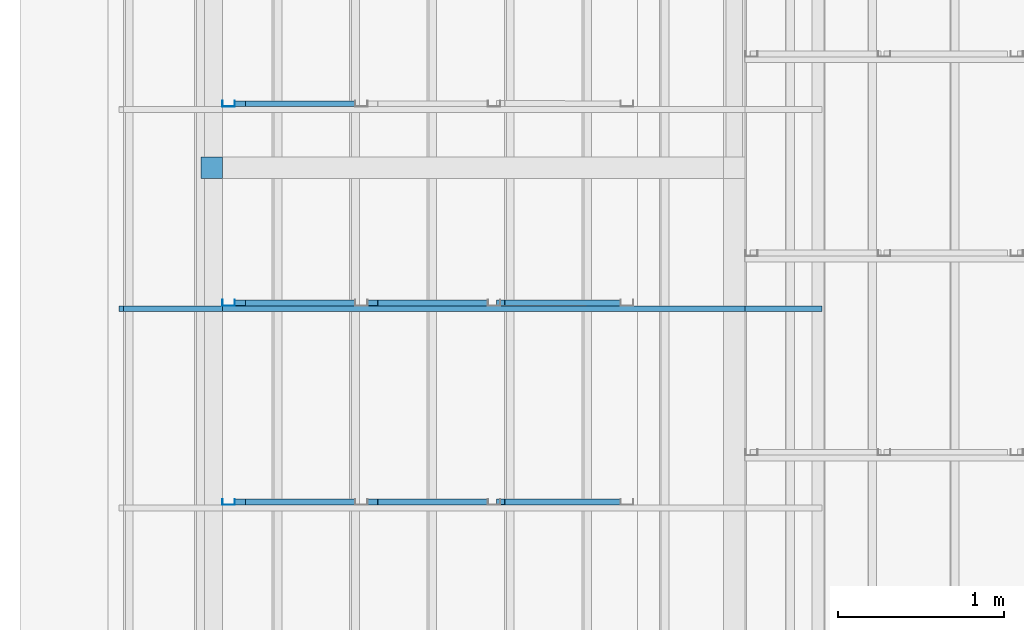
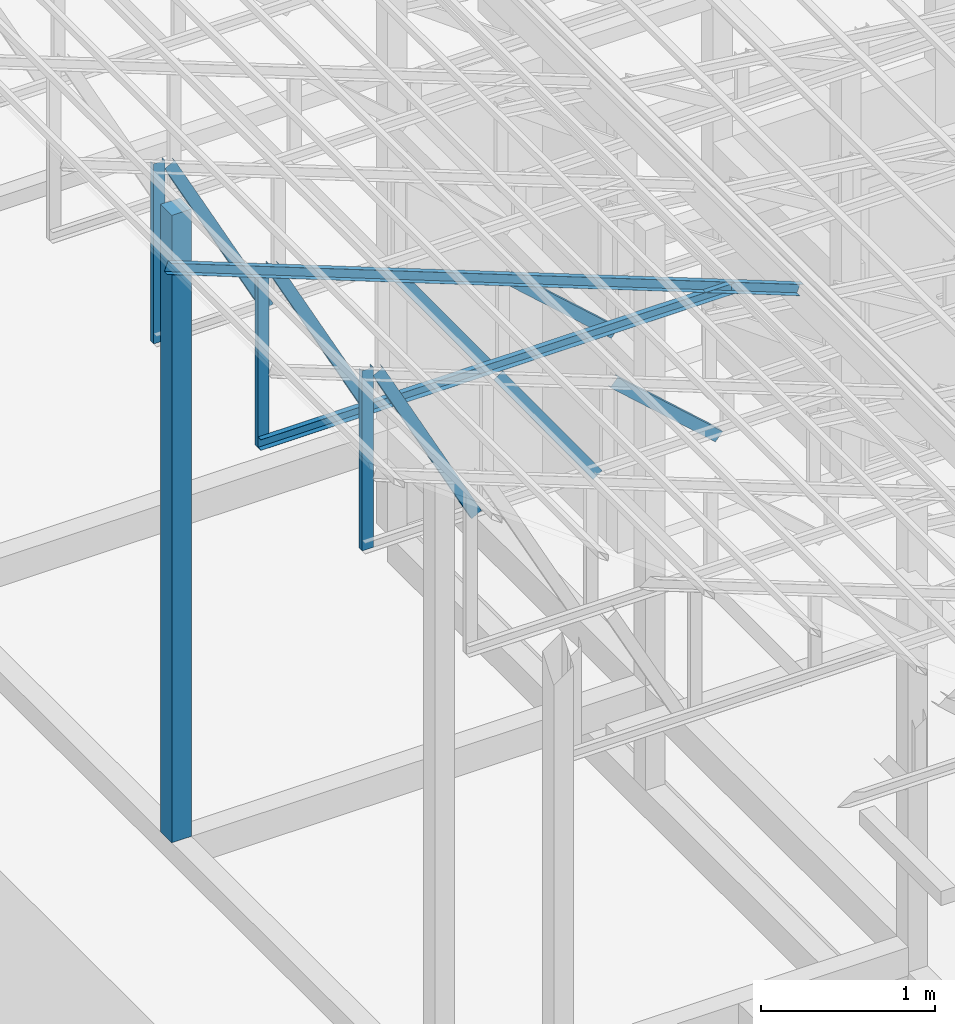
# One storey, part 11 of 22: 12 members, 1 beam, 1 element without a shape of its own.
"""IFC4 building model written with IfcOpenShell, lengths in millimetres."""

from ifc_helpers import new_model, entity, si_unit, converted_unit, frame, origin_with_axes, origin_2d_with_axis, place, context, subcontext, project, spatial, rectangle, c_section, extrude, material, material_profile, profile_set, profile_usage, type_object, element, aggregate, save


model = new_model("IFC4")

# Units and contexts
model_context = context("Model", 3, precision=1e-05, world=origin_with_axes())
plan_context = context("Plan", 2, precision=1e-05, world=origin_2d_with_axis())
body_context = subcontext(model_context, "Body", "Model", "MODEL_VIEW")
ifc_project = project(units=[si_unit("VOLUMEUNIT", "CUBIC_METRE"), si_unit("LENGTHUNIT", "METRE", prefix="MILLI"), si_unit("AREAUNIT", "SQUARE_METRE"), converted_unit("PLANEANGLEUNIT", "degree", entity("IfcReal", 0.0174532925199433), si_unit("PLANEANGLEUNIT", "RADIAN"), dimensions=[0, 0, 0, 0, 0, 0, 0])], contexts=[model_context, plan_context])

# Site, building, storey
site_placement = place(None, origin_with_axes())
site = spatial("IfcSite", under=ifc_project, at=site_placement)
building_placement = place(site_placement, origin_with_axes())
building = spatial("IfcBuilding", under=site, at=building_placement, Name="2")
storey_placement = place(building_placement, frame((0.0, 0.0, 200.000002980232), z_axis=(0.0, 0.0, 1.0), x_axis=(1.0, 0.0, 0.0)))
storey = spatial("IfcBuildingStorey", under=building, at=storey_placement)

# Beam
ifc_material_1 = material(Name="Concrete")
ifc_material_profile_1 = material_profile(ifc_material_1, rectangle(XDim=130.000015258789, YDim=130.000015258789, kind="CURVE"))
ifc_profile_set_1 = profile_set([ifc_material_profile_1])
ifc_profile_usage_1 = profile_usage(ifc_profile_set_1, cardinal=5)
beam_type = type_object("IfcBeamType", PredefinedType="BEAM", material=ifc_profile_set_1)
beam_placement = place(storey_placement, frame((-7149.99771118164, 14330.0046920776, 735.000059008599), z_axis=(0.0, 0.0, 1.0), x_axis=(1.0, 0.0, 0.0)))
element("IfcBeam", 1, at=beam_placement, inside=storey, type_object=beam_type, material=ifc_profile_usage_1, Name="Column", PredefinedType="BEAM", context=body_context, shape_type="SweptSolid", body=[
    extrude(rectangle(XDim=130.000015258789, YDim=130.000015258789, kind="CURVE"), origin_with_axes(), (0.0, 0.0, 1.0), 4411.20902133499),
])

# Assembly, members
assembly_placement = place(storey_placement, frame((-3938.51041793823, 5099.00283813477, 3935.3459328413), z_axis=(0.0, 0.0, 1.0), x_axis=(1.0, 0.0, 0.0)))
assembly = element("IfcElementAssembly", 2, at=assembly_placement, inside=storey, Name="2")
ifc_material_2 = material(Name="STEEL")
ifc_material_profile_2 = material_profile(ifc_material_2, c_section(Depth=75.0, Width=35.0, WallThickness=1.0, Girth=1.0, kind="CURVE"))
ifc_profile_set_2 = profile_set([ifc_material_profile_2])
ifc_profile_usage_2 = profile_usage(ifc_profile_set_2, cardinal=3)
member_type = type_object("IfcMemberType", Name="C75", PredefinedType="CHORD", material=ifc_profile_set_2)
member_1_placement = place(assembly_placement, frame((-2271.51107788086, 7199.99885559082, 894.618034362793), z_axis=(0.578723368640778, -7.49756619914683e-07, -0.815523919078103), x_axis=(1.02917226740772e-06, 0.999999999999453, -1.89020340712783e-07)))
member_1 = element("IfcMember", 3, at=member_1_placement, type_object=member_type, material=ifc_profile_usage_2, Name="Member", context=body_context, shape_type="SweptSolid", body=[
    extrude(c_section(Depth=75.0, Width=35.0, WallThickness=1.0, Girth=1.0, kind="CURVE"), frame((17.5, 37.5, 0.0), z_axis=(0.0, 0.0, 1.0), x_axis=(1.0, 0.0, 0.0)), (0.0, 0.0, 1.0), 1142.30360336039),
])
ifc_profile_usage_3 = profile_usage(ifc_profile_set_2, cardinal=1)
member_2_placement = place(assembly_placement, frame((-3146.51107788086, 7234.99774932861, 1265.15865325928), z_axis=(-8.74227410463377e-08, -1.50995830949794e-07, -0.999999999999985), x_axis=(-3.13916473260159e-07, 0.999999999999939, -1.50995802528077e-07)))
member_2 = element("IfcMember", 4, at=member_2_placement, type_object=member_type, material=ifc_profile_usage_3, Name="Member", context=body_context, shape_type="SweptSolid", body=[
    extrude(c_section(Depth=75.0, Width=35.0, WallThickness=1.0, Girth=1.0, kind="CURVE"), frame((-17.5, 37.5, 0.0), z_axis=(0.0, 0.0, 1.0), x_axis=(1.0, 0.0, 0.0)), (0.0, 0.0, 1.0), 1266.51238309135),
])
ifc_profile_usage_4 = profile_usage(ifc_profile_set_2, cardinal=7)
member_3_placement = place(assembly_placement, frame((-1445.26290893555, 7235.96000671387, 624.074935913086), z_axis=(0.745142107017777, -0.00102660805644996, -0.66690493057482), x_axis=(0.00137753843534741, 0.999999051193456, -2.17762747561669e-07)))
member_3 = element("IfcMember", 5, at=member_3_placement, type_object=member_type, material=ifc_profile_usage_4, Name="Member", context=body_context, shape_type="SweptSolid", body=[
    extrude(c_section(Depth=75.0, Width=35.0, WallThickness=1.0, Girth=1.0, kind="CURVE"), frame((-17.5, -37.5, 0.0), z_axis=(0.0, 0.0, 1.0), x_axis=(1.0, 0.0, 0.0)), (0.0, 0.0, 1.0), 937.808496265298),
])
ifc_profile_usage_5 = profile_usage(ifc_profile_set_2, cardinal=9)
member_4_placement = place(assembly_placement, frame((-3006.42156600952, 7199.9979019165, 1241.45650863647), z_axis=(0.468464370953309, -3.43728484817469e-07, -0.88348238983423), x_axis=(6.7154434191237e-07, 0.999999999999774, -3.29761675743537e-08)))
member_4 = element("IfcMember", 6, at=member_4_placement, type_object=member_type, material=ifc_profile_usage_5, Name="Member", context=body_context, shape_type="SweptSolid", body=[
    extrude(c_section(Depth=75.0, Width=35.0, WallThickness=1.0, Girth=1.0, kind="CURVE"), frame((17.5, -37.5, 0.0), z_axis=(0.0, 0.0, 1.0), x_axis=(1.0, 0.0, 0.0)), (0.0, 0.0, 1.0), 1399.63894386164),
])
ifc_profile_usage_6 = profile_usage(ifc_profile_set_2, cardinal=3)
member_5_placement = place(assembly_placement, frame((-2271.51107788086, 8399.99866485596, 894.618034362793), z_axis=(0.578723368640778, -7.49756619914683e-07, -0.815523919078103), x_axis=(1.02917226740772e-06, 0.999999999999453, -1.89020340712783e-07)))
member_5 = element("IfcMember", 7, at=member_5_placement, type_object=member_type, material=ifc_profile_usage_6, Name="Member", context=body_context, shape_type="SweptSolid", body=[
    extrude(c_section(Depth=75.0, Width=35.0, WallThickness=1.0, Girth=1.0, kind="CURVE"), frame((17.5, 37.5, 0.0), z_axis=(0.0, 0.0, 1.0), x_axis=(1.0, 0.0, 0.0)), (0.0, 0.0, 1.0), 1142.30360336039),
])
ifc_profile_usage_7 = profile_usage(ifc_profile_set_2, cardinal=1)
member_6_placement = place(assembly_placement, frame((-3146.51107788086, 8434.99755859375, 1265.15865325928), z_axis=(-8.74227410463377e-08, -1.50995830949794e-07, -0.999999999999985), x_axis=(-3.13916473260159e-07, 0.999999999999939, -1.50995802528077e-07)))
member_6 = element("IfcMember", 8, at=member_6_placement, type_object=member_type, material=ifc_profile_usage_7, Name="Member", context=body_context, shape_type="SweptSolid", body=[
    extrude(c_section(Depth=75.0, Width=35.0, WallThickness=1.0, Girth=1.0, kind="CURVE"), frame((-17.5, 37.5, 0.0), z_axis=(0.0, 0.0, 1.0), x_axis=(1.0, 0.0, 0.0)), (0.0, 0.0, 1.0), 1266.51238309135),
])
ifc_profile_usage_8 = profile_usage(ifc_profile_set_2, cardinal=1)
member_7_placement = place(assembly_placement, frame((438.234329223633, 8364.99977111816, -169.034004211426), z_axis=(-0.933001152035968, -8.32115964913738e-07, 0.359873380925658), x_axis=(9.09962921013707e-07, -0.999999999999585, 4.6906695416718e-08)))
member_7 = element("IfcMember", 9, at=member_7_placement, type_object=member_type, material=ifc_profile_usage_8, Name="Member", context=body_context, shape_type="SweptSolid", body=[
    extrude(c_section(Depth=75.0, Width=35.0, WallThickness=1.0, Girth=1.0, kind="CURVE"), frame((-17.5, 37.5, 0.0), z_axis=(0.0, 0.0, 1.0), x_axis=(1.0, 0.0, 0.0)), (0.0, 0.0, 1.0), 4510.0754953159),
])
ifc_profile_usage_9 = profile_usage(ifc_profile_set_2, cardinal=1)
member_8_placement = place(assembly_placement, frame((3.51285934448242, 8364.99881744385, -1.35517120361328), z_axis=(-0.999999999999812, -4.33125762810878e-07, 4.33125762810878e-07), x_axis=(4.33125762810919e-07, -0.999999999999906, -1.13742348872837e-13)))
member_8 = element("IfcMember", 10, at=member_8_placement, type_object=member_type, material=ifc_profile_usage_9, Name="Member", context=body_context, shape_type="SweptSolid", body=[
    extrude(c_section(Depth=75.0, Width=35.0, WallThickness=1.0, Girth=1.0, kind="CURVE"), frame((-17.5, 37.5, 0.0), z_axis=(0.0, 0.0, 1.0), x_axis=(1.0, 0.0, 0.0)), (0.0, 0.0, 1.0), 3150.02386296032),
])
ifc_profile_usage_10 = profile_usage(ifc_profile_set_2, cardinal=7)
member_9_placement = place(assembly_placement, frame((-1445.26290893555, 8435.959815979, 624.074935913086), z_axis=(0.745142107017777, -0.00102660805644996, -0.66690493057482), x_axis=(0.00137753843534741, 0.999999051193456, -2.17762747561669e-07)))
member_9 = element("IfcMember", 11, at=member_9_placement, type_object=member_type, material=ifc_profile_usage_10, Name="Member", context=body_context, shape_type="SweptSolid", body=[
    extrude(c_section(Depth=75.0, Width=35.0, WallThickness=1.0, Girth=1.0, kind="CURVE"), frame((-17.5, -37.5, 0.0), z_axis=(0.0, 0.0, 1.0), x_axis=(1.0, 0.0, 0.0)), (0.0, 0.0, 1.0), 937.808496265298),
])
ifc_profile_usage_11 = profile_usage(ifc_profile_set_2, cardinal=9)
member_10_placement = place(assembly_placement, frame((-3006.42156600952, 8399.99771118164, 1241.45650863647), z_axis=(0.468464370953309, -3.43728484817469e-07, -0.88348238983423), x_axis=(6.7154434191237e-07, 0.999999999999774, -3.29761675743537e-08)))
member_10 = element("IfcMember", 12, at=member_10_placement, type_object=member_type, material=ifc_profile_usage_11, Name="Member", context=body_context, shape_type="SweptSolid", body=[
    extrude(c_section(Depth=75.0, Width=35.0, WallThickness=1.0, Girth=1.0, kind="CURVE"), frame((17.5, -37.5, 0.0), z_axis=(0.0, 0.0, 1.0), x_axis=(1.0, 0.0, 0.0)), (0.0, 0.0, 1.0), 1399.63894386164),
])
ifc_profile_usage_12 = profile_usage(ifc_profile_set_2, cardinal=9)
member_11_placement = place(assembly_placement, frame((-3006.42156600952, 9599.99752044678, 1241.45650863647), z_axis=(0.468464370953309, -3.43728484817469e-07, -0.88348238983423), x_axis=(6.7154434191237e-07, 0.999999999999774, -3.29761675743537e-08)))
member_11 = element("IfcMember", 13, at=member_11_placement, type_object=member_type, material=ifc_profile_usage_12, Name="Member", context=body_context, shape_type="SweptSolid", body=[
    extrude(c_section(Depth=75.0, Width=35.0, WallThickness=1.0, Girth=1.0, kind="CURVE"), frame((17.5, -37.5, 0.0), z_axis=(0.0, 0.0, 1.0), x_axis=(1.0, 0.0, 0.0)), (0.0, 0.0, 1.0), 1399.63894386164),
])
ifc_profile_usage_13 = profile_usage(ifc_profile_set_2, cardinal=1)
member_12_placement = place(assembly_placement, frame((-3146.51107788086, 9634.99736785889, 1265.15865325928), z_axis=(-8.74227410463377e-08, -1.50995830949794e-07, -0.999999999999985), x_axis=(-3.13916473260159e-07, 0.999999999999939, -1.50995802528077e-07)))
member_12 = element("IfcMember", 14, at=member_12_placement, type_object=member_type, material=ifc_profile_usage_13, Name="Member", context=body_context, shape_type="SweptSolid", body=[
    extrude(c_section(Depth=75.0, Width=35.0, WallThickness=1.0, Girth=1.0, kind="CURVE"), frame((-17.5, 37.5, 0.0), z_axis=(0.0, 0.0, 1.0), x_axis=(1.0, 0.0, 0.0)), (0.0, 0.0, 1.0), 1266.51238309135),
])
aggregate(assembly, [member_1, member_2, member_3, member_4, member_5, member_6, member_7, member_8, member_9, member_10, member_11, member_12])

save(model, "model.ifc")
